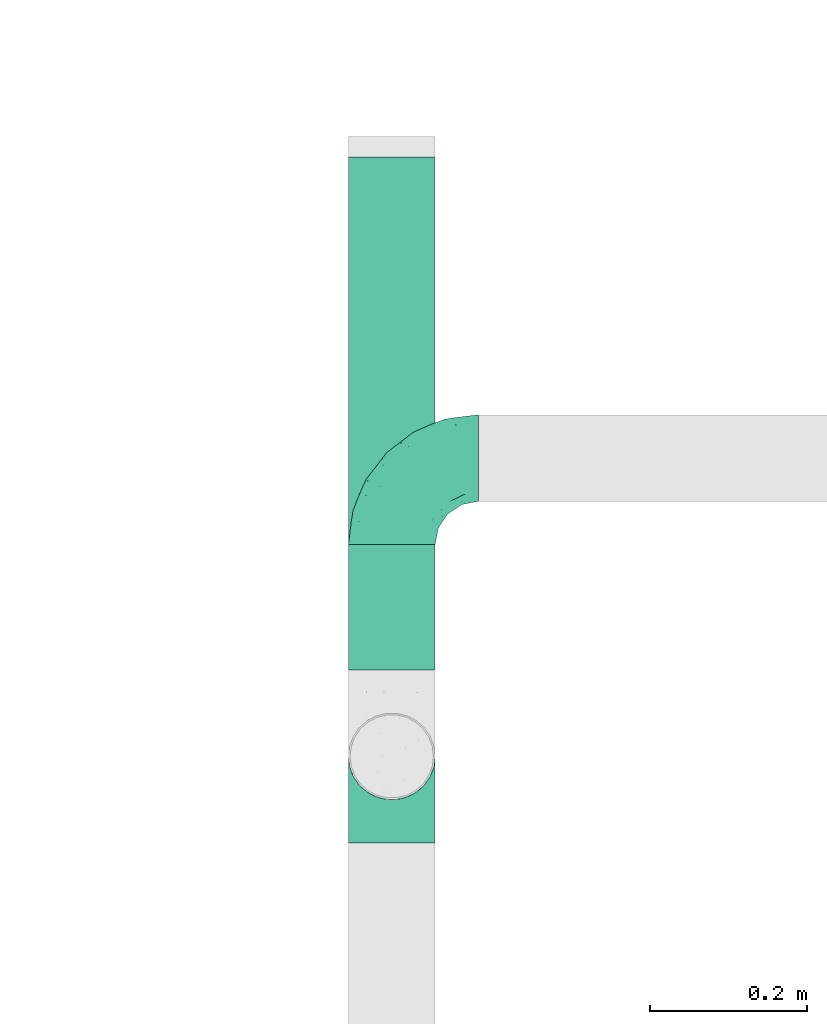
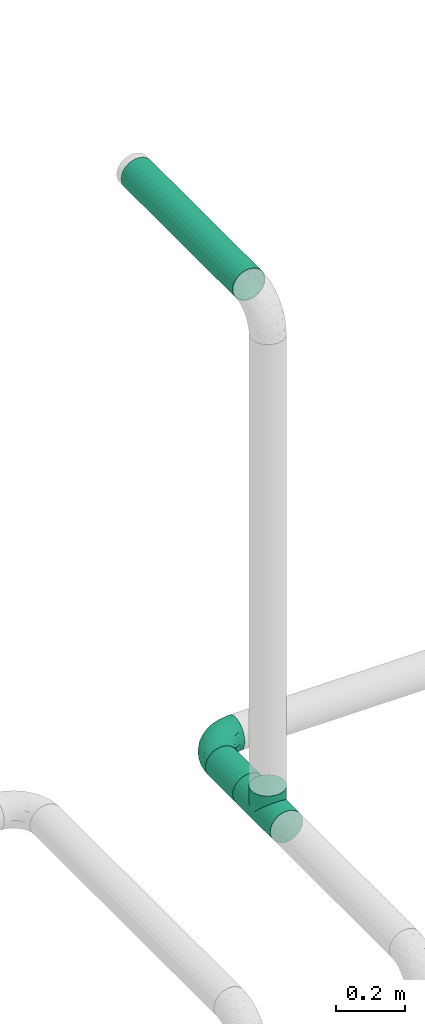
# One storey, part 81 of 103: 2 flow fittings, 2 flow segments.
"""IFC2X3 building model written with IfcOpenShell, lengths in millimetres."""

import ifcopenshell
import ifcopenshell.guid

model = None  # the IFC model being written
_history = None  # IfcOwnerHistory: only IFC2X3 demands one
_inside = {}  # id of a spatial element -> (the spatial element, [elements in it])
_under = {}  # id of a project, library or spatial element -> (it, [spatial elements below it])
_declared = {}  # id of a project -> (the project, [libraries it declares])
_typed = {}  # id of a type object -> (the type object, [elements of that type])
_made_of = {}  # id of a material, layer set ... -> (it, [elements and type objects made of it])


def new_model(schema):
    """Start an empty IFC model of exactly this schema.

    Asked for "IFC4X3", IfcOpenShell would pick the latest addendum, in which some entities
    have other attributes; the version numbers below select the first issue.
    IFC2X3 requires an IfcOwnerHistory on every rooted entity: one is made here for all.
    """
    global model, _history
    if schema == "IFC4X3":
        model = ifcopenshell.file(schema_version=(4, 3, 0, 0))
    else:
        model = ifcopenshell.file(schema=schema)
    _inside.clear()
    _under.clear()
    _declared.clear()
    _typed.clear()
    _made_of.clear()
    _history = None
    if model.schema == "IFC2X3":
        org = make("IfcOrganization", Name="unknown")
        user = make(
            "IfcPersonAndOrganization",
            ThePerson=make("IfcPerson", FamilyName="unknown"),
            TheOrganization=org,
        )
        app = make(
            "IfcApplication",
            ApplicationDeveloper=org,
            Version="unknown",
            ApplicationFullName="unknown",
            ApplicationIdentifier="unknown",
        )
        _history = make(
            "IfcOwnerHistory",
            OwningUser=user,
            OwningApplication=app,
            ChangeAction="ADDED",
            CreationDate=0,
        )
    return model


def make(cls, **values):
    """One entity of the class cls with the attributes given. An attribute that is None is left unset."""
    return model.create_entity(
        cls, **{name: value for name, value in values.items() if value is not None}
    )


def entity(cls, *values):
    """Any entity or typed value of the class cls, its attributes in the order of the schema. None: left unset."""
    e = model.create_entity(cls)
    for i, value in enumerate(values):
        if value is not None:
            e[i] = value
    return e


def rooted(cls, **values):
    """An entity with a GlobalId (a new one), such as an element, a storey or a relation."""
    return make(cls, GlobalId=ifcopenshell.guid.new(), OwnerHistory=_history, **values)


def si_unit(unit_type, name, prefix=None):
    """IfcSIUnit, for example si_unit("LENGTHUNIT", "METRE", prefix="MILLI")."""
    return make("IfcSIUnit", UnitType=unit_type, Prefix=prefix, Name=name)


def converted_unit(unit_type, name, factor, base, dimensions=None, offset=None):
    """IfcConversionBasedUnit, such as the inch: factor (a typed value) times the base unit."""
    return make(
        "IfcConversionBasedUnit"
        if offset is None
        else "IfcConversionBasedUnitWithOffset",
        ConversionOffset=offset,
        Dimensions=None
        if dimensions is None
        else entity("IfcDimensionalExponents", *dimensions),
        UnitType=unit_type,
        Name=name,
        ConversionFactor=make(
            "IfcMeasureWithUnit", ValueComponent=factor, UnitComponent=base
        ),
    )


def derived_unit(unit_type, elements):
    """IfcDerivedUnit: a product of units, each with its exponent."""
    return make(
        "IfcDerivedUnit",
        Elements=[
            make("IfcDerivedUnitElement", Unit=unit, Exponent=power)
            for unit, power in elements
        ],
        UnitType=unit_type,
    )


def assignment(units):
    """IfcUnitAssignment: the units of a project."""
    return None if units is None else make("IfcUnitAssignment", Units=units)


def point(xyz):
    """IfcCartesianPoint."""
    return None if xyz is None else make("IfcCartesianPoint", Coordinates=xyz)


def direction(xyz):
    """IfcDirection."""
    return None if xyz is None else make("IfcDirection", DirectionRatios=xyz)


def frame(location, z_axis=None, x_axis=None):
    """IfcAxis2Placement3D, a coordinate frame: its origin and axes. An axis left out is left unset."""
    return make(
        "IfcAxis2Placement3D",
        Location=point(location),
        Axis=direction(z_axis),
        RefDirection=direction(x_axis),
    )


def frame_2d(location, x_axis=None):
    """IfcAxis2Placement2D, a coordinate frame in the plane: its origin and x axis."""
    return make(
        "IfcAxis2Placement2D", Location=point(location), RefDirection=direction(x_axis)
    )


def origin_with_axes():
    """The frame at (0, 0, 0) with the z axis (0, 0, 1) and the x axis (1, 0, 0) written out."""
    return frame((0.0, 0.0, 0.0), z_axis=(0.0, 0.0, 1.0), x_axis=(1.0, 0.0, 0.0))


def origin_2d_with_axis():
    """The frame at (0, 0) in the plane with the x axis (1, 0) written out."""
    return frame_2d((0.0, 0.0), x_axis=(1.0, 0.0))


def place(relative_to, where):
    """IfcLocalPlacement: puts the frame where relative to a parent placement (None: the world)."""
    return make(
        "IfcLocalPlacement", PlacementRelTo=relative_to, RelativePlacement=where
    )


def context(
    kind, dimensions, precision=None, world=None, true_north=None, identifier=None
):
    """IfcGeometricRepresentationContext, for example the 3D "Model" context."""
    return make(
        "IfcGeometricRepresentationContext",
        ContextIdentifier=identifier,
        ContextType=kind,
        CoordinateSpaceDimension=dimensions,
        Precision=precision,
        WorldCoordinateSystem=world,
        TrueNorth=true_north,
    )


def subcontext(parent, identifier, kind, view, scale=None):
    """IfcGeometricRepresentationSubContext, for example "Body" below "Model"."""
    return make(
        "IfcGeometricRepresentationSubContext",
        ContextIdentifier=identifier,
        ContextType=kind,
        ParentContext=parent,
        TargetScale=scale,
        TargetView=view,
    )


def project(units=None, contexts=None):
    """IfcProject with its units and contexts."""
    return rooted(
        "IfcProject",
        Name="project",
        RepresentationContexts=contexts,
        UnitsInContext=assignment(units),
    )


def spatial(cls, under=None, at=None, **own):
    """A site, building, storey or space (cls), placed at a placement, below another one or the project."""
    s = rooted(cls, ObjectPlacement=at, **own)
    if under is not None:
        _under.setdefault(under.id(), (under, []))[1].append(s)
    return s


def profile(cls, at=None, kind="AREA", **sizes):
    """A parametric profile (cls). Its sizes go by their IFC names, for example OverallWidth=200.0."""
    return make(cls, ProfileType=kind, Position=at, **sizes)


def hollow_circle(**sizes):
    """IfcCircleHollowProfileDef."""
    return profile("IfcCircleHollowProfileDef", **sizes)


def extrude(swept, where, along, depth):
    """IfcExtrudedAreaSolid: the profile swept, set in the frame where, extruded along a direction by depth."""
    return make(
        "IfcExtrudedAreaSolid",
        SweptArea=swept,
        Position=where,
        ExtrudedDirection=direction(along),
        Depth=depth,
    )


def faces_of(points, faces, orient=None, outer=None):
    """IfcFace entities. A face is a list of loops; a loop is a list of indices into points, from 0.

    orient and outer hold one flag for each loop. By default every Orientation is true, the
    first loop of a face is its IfcFaceOuterBound and the others are IfcFaceBound.
    """
    made = []
    for i, loops in enumerate(faces):
        bounds = []
        for j, loop in enumerate(loops):
            is_outer = j == 0 if outer is None else outer[i][j]
            bounds.append(
                make(
                    "IfcFaceOuterBound" if is_outer else "IfcFaceBound",
                    Bound=make("IfcPolyLoop", Polygon=[points[k] for k in loop]),
                    Orientation=True if orient is None else orient[i][j],
                )
            )
        made.append(make("IfcFace", Bounds=bounds))
    return made


def open_shell(faces, orient=None, outer=None):
    """The faces of one IfcOpenShell. surface_model builds it on its shared points."""
    return ("IfcOpenShell", faces, orient, outer)


def surface_model(cls, points, shells):
    """IfcFaceBasedSurfaceModel or IfcShellBasedSurfaceModel (cls): surfaces that need not close."""
    shared = [point(p) for p in points]
    made = [make(c, CfsFaces=faces_of(shared, fs, o, b)) for c, fs, o, b in shells]
    if cls == "IfcFaceBasedSurfaceModel":
        return make(cls, FbsmFaces=made)
    return make(cls, SbsmBoundary=made)


def shape(context_of_items, identifier, shape_type, items):
    """IfcShapeRepresentation: the items that make up one representation, for example the "Body"."""
    return make(
        "IfcShapeRepresentation",
        ContextOfItems=context_of_items,
        RepresentationIdentifier=identifier,
        RepresentationType=shape_type,
        Items=items,
    )


def source(mapping_origin, context_of_items, identifier, shape_type, items):
    """IfcRepresentationMap: a shape defined once, which mapped items show again and again."""
    return make(
        "IfcRepresentationMap",
        MappingOrigin=mapping_origin,
        MappedRepresentation=shape(context_of_items, identifier, shape_type, items),
    )


def transform(
    local_origin,
    x_axis=None,
    y_axis=None,
    z_axis=None,
    scale=None,
    scale2=None,
    scale3=None,
    uniform=True,
):
    """IfcCartesianTransformationOperator3D, or its non-uniform kind. x_axis, y_axis, z_axis: its Axis1, 2, 3."""
    if uniform:
        return make(
            "IfcCartesianTransformationOperator3D",
            Axis1=direction(x_axis),
            Axis2=direction(y_axis),
            LocalOrigin=point(local_origin),
            Scale=scale,
            Axis3=direction(z_axis),
        )
    return make(
        "IfcCartesianTransformationOperator3DnonUniform",
        Axis1=direction(x_axis),
        Axis2=direction(y_axis),
        LocalOrigin=point(local_origin),
        Scale=scale,
        Axis3=direction(z_axis),
        Scale2=scale2,
        Scale3=scale3,
    )


def mapped(mapping_source, mapping_target):
    """IfcMappedItem: shows the shape of a source again, moved by a transform."""
    return make(
        "IfcMappedItem", MappingSource=mapping_source, MappingTarget=mapping_target
    )


def material(Name=None, Category=None):
    """IfcMaterial."""
    return make("IfcMaterial", Name=Name, Category=Category)


def layer(
    of_material, thickness, ventilated=None, Name=None, Category=None, Priority=None
):
    """IfcMaterialLayer: one layer of a wall or slab, of a material (None: an air gap)."""
    return make(
        "IfcMaterialLayer",
        Material=of_material,
        LayerThickness=thickness,
        IsVentilated=ventilated,
        Name=Name,
        Category=Category,
        Priority=Priority,
    )


def layer_set(layers, Name=None):
    """IfcMaterialLayerSet."""
    return make("IfcMaterialLayerSet", MaterialLayers=layers, LayerSetName=Name)


def layer_usage(for_layer_set, set_direction, sense, offset, extent=None):
    """IfcMaterialLayerSetUsage: how a layer set lies in its element."""
    return make(
        "IfcMaterialLayerSetUsage",
        ForLayerSet=for_layer_set,
        LayerSetDirection=set_direction,
        DirectionSense=sense,
        OffsetFromReferenceLine=offset,
        ReferenceExtent=extent,
    )


def made_of(thing, what):
    """Note that an element or type object is made of a material, layer set ...; save() writes the relation."""
    if what is not None:
        _made_of.setdefault(what.id(), (what, []))[1].append(thing)
    return thing


def type_object(cls, material=None, **own):
    """A type object (cls), such as IfcWallType, which elements share."""
    return made_of(rooted(cls, **own), material)


def element(
    cls,
    number,
    at=None,
    inside=None,
    cuts=None,
    type_object=None,
    material=None,
    context=None,
    identifier="Body",
    shape_type=None,
    held_by="IfcProductDefinitionShape",
    body=None,
    shapes=None,
    **own,
):
    """One element of the class cls, such as IfcWall. Its Tag is "e" and its number.

    at: its placement. inside: the storey or other place that contains it. cuts: it is an
    opening in that element (IfcRelVoidsElement). A single representation is given by context,
    identifier, shape_type and body (its items); several are given by shapes. held_by: the class
    of the entity that holds the representations. save() writes the other relations.
    """
    e = rooted(cls, Tag="e%d" % number, ObjectPlacement=at, **own)
    if body is not None:
        shapes = [shape(context, identifier, shape_type, body)]
    if shapes is not None:
        e.Representation = make(held_by, Representations=shapes)
    if inside is not None:
        _inside.setdefault(inside.id(), (inside, []))[1].append(e)
    if cuts is not None:
        rooted(
            "IfcRelVoidsElement", RelatingBuildingElement=cuts, RelatedOpeningElement=e
        )
    if type_object is not None:
        _typed.setdefault(type_object.id(), (type_object, []))[1].append(e)
    return made_of(e, material)


def aggregate(whole, parts):
    """IfcRelAggregates: a whole, such as a stair, and the parts it consists of."""
    return rooted("IfcRelAggregates", RelatingObject=whole, RelatedObjects=parts)


def save(model, path):
    """Write the relations noted so far, then the file.

    IfcRelAggregates (storeys below a building ...), IfcRelContainedInSpatialStructure (elements
    in a storey), IfcRelDefinesByType, IfcRelAssociatesMaterial and IfcRelDeclares: one each for
    every whole, place, type object, material and project.
    """
    for whole, parts in _under.values():
        aggregate(whole, parts)
    for where, things in _inside.values():
        rooted(
            "IfcRelContainedInSpatialStructure",
            RelatedElements=things,
            RelatingStructure=where,
        )
    for kind, things in _typed.values():
        rooted("IfcRelDefinesByType", RelatedObjects=things, RelatingType=kind)
    for what, things in _made_of.values():
        rooted("IfcRelAssociatesMaterial", RelatedObjects=things, RelatingMaterial=what)
    for by, libraries in _declared.values():
        rooted("IfcRelDeclares", RelatingContext=by, RelatedDefinitions=libraries)
    model.write(path)


model = new_model("IFC2X3")

# Units and contexts
model_context = context("Model", 3, precision=1e-05, world=origin_with_axes(), true_north=direction((0.0, 1.0)))
body_context = subcontext(model_context, "Body", "Model", "MODEL_VIEW")
ifc_project = project(units=[si_unit("AREAUNIT", "SQUARE_METRE"), si_unit("VOLUMEUNIT", "CUBIC_METRE", prefix="DECI"), si_unit("TIMEUNIT", "SECOND"), si_unit("THERMODYNAMICTEMPERATUREUNIT", "DEGREE_CELSIUS"), si_unit("PRESSUREUNIT", "PASCAL"), si_unit("MASSUNIT", "GRAM", prefix="KILO"), si_unit("LENGTHUNIT", "METRE", prefix="MILLI"), si_unit("POWERUNIT", "WATT"), si_unit("ELECTRICCURRENTUNIT", "AMPERE"), si_unit("ELECTRICVOLTAGEUNIT", "VOLT"), derived_unit("VOLUMETRICFLOWRATEUNIT", [(si_unit("VOLUMEUNIT", "CUBIC_METRE", prefix="DECI"), 1), (si_unit("TIMEUNIT", "SECOND"), -1)]), derived_unit("LINEARVELOCITYUNIT", [(si_unit("LENGTHUNIT", "METRE"), 1), (si_unit("TIMEUNIT", "SECOND"), -1)]), derived_unit("MASSDENSITYUNIT", [(si_unit("MASSUNIT", "GRAM", prefix="KILO"), 1), (si_unit("VOLUMEUNIT", "CUBIC_METRE"), -1)]), converted_unit("PLANEANGLEUNIT", "DEGREE", entity("IfcRatioMeasure", 0.01745), si_unit("PLANEANGLEUNIT", "RADIAN"), dimensions=[0, 0, 0, 0, 0, 0, 0])], contexts=[model_context])

# Site, building, storey
site_placement = place(None, origin_with_axes())
site = spatial("IfcSite", under=ifc_project, at=site_placement, CompositionType="ELEMENT")
building_placement = place(site_placement, origin_with_axes())
building = spatial("IfcBuilding", under=site, at=building_placement, Name="mc-building", CompositionType="ELEMENT")
storey_placement = place(building_placement, frame((0.0, 0.0, 5900.0), z_axis=(0.0, 0.0, 1.0), x_axis=(1.0, 0.0, 0.0)))
storey = spatial("IfcBuildingStorey", under=building, at=storey_placement, Name="3. Korrus", CompositionType="ELEMENT", Elevation=5900.0)

# Flow fittings
duct_fitting_type_1 = type_object("IfcDuctFittingType", PredefinedType="JUNCTION")
shared_shape_1 = source(origin_with_axes(), body_context, "Body", "SurfaceModel", [
    surface_model("IfcShellBasedSurfaceModel", [(0.0, -80.0, -55.0), (14.23505, -80.0, -53.12592), (-14.23505, -80.0, -53.12592), (-53.12592, -80.0, 14.23505), (-27.5, -80.0, -47.63139), (-47.63139, -80.0, -27.5), (-38.89087, -80.0, -38.89087), (55.0, -80.0, 0.0), (53.12592, -80.0, 14.23505), (38.89087, -80.0, -38.89087), (27.5, -80.0, -47.63139), (53.12592, -80.0, -14.23505), (47.63139, -80.0, -27.5), (-53.12592, -80.0, -14.23505), (-47.63139, -80.0, 27.5), (-38.89087, -80.0, 38.89087), (14.23505, -80.0, 53.12592), (-27.5, -80.0, 47.63139), (-14.23505, -80.0, 53.12592), (47.63139, -80.0, 27.5), (38.89087, -80.0, 38.89087), (27.5, -80.0, 47.63139), (0.0, -80.0, 55.0), (-55.0, -80.0, 0.0), (0.0, 0.0, 55.0), (-7.4066, -7.4066, 54.49901), (-14.74521, -14.74521, 52.98659), (-21.93978, -21.93978, 50.43457), (-28.89905, -28.89905, 46.79578), (-35.50357, -35.50357, 42.00591), (-41.58668, -41.58668, 35.99373), (-46.92319, -46.92319, 28.69171), (-51.19777, -51.19777, 20.0945), (-50.37866, -80.0, 20.86752), (-54.01174, -54.01174, 10.37938), (-55.0, -55.0, 0.0), (-54.06296, -80.0, 7.11752), (-54.01174, -54.01174, -10.37938), (-51.19777, -51.19777, -20.0945), (-54.06296, -80.0, -7.11752), (-46.92319, -46.92319, -28.69171), (-41.58668, -41.58668, -35.99373), (-50.37866, -80.0, -20.86752), (-35.50357, -35.50357, -42.00591), (-21.93978, -21.93978, -50.43457), (-14.74521, -14.74521, -52.98659), (-7.4066, -7.4066, -54.49901), (0.0, 0.0, -55.0), (-28.89905, -28.89905, -46.79578), (7.4066, -7.4066, -54.49901), (14.74521, -14.74521, -52.98659), (21.93978, -21.93978, -50.43457), (28.89905, -28.89905, -46.79578), (35.50357, -35.50357, -42.00591), (41.58668, -41.58668, -35.99373), (46.92319, -46.92319, -28.69171), (51.19777, -51.19777, -20.0945), (50.37866, -80.0, -20.86752), (54.01174, -54.01174, -10.37938), (55.0, -55.0, 0.0), (54.06296, -80.0, -7.11752), (54.01174, -54.01174, 10.37938), (51.19777, -51.19777, 20.0945), (54.06296, -80.0, 7.11752), (46.92319, -46.92319, 28.69171), (41.58668, -41.58668, 35.99373), (50.37866, -80.0, 20.86752), (35.50357, -35.50357, 42.00591), (21.93978, -21.93978, 50.43457), (14.74521, -14.74521, 52.98659), (7.4066, -7.4066, 54.49901), (28.89905, -28.89905, 46.79578), (-110.0, 0.0, -55.0), (-110.0, -14.23505, -53.12592), (-110.0, 14.23505, -53.12592), (-110.0, 53.12592, 14.23505), (-110.0, 27.5, -47.63139), (-110.0, 47.63139, -27.5), (-110.0, 38.89087, -38.89087), (-110.0, -55.0, 0.0), (-110.0, -53.12592, 14.23505), (-110.0, -38.89087, -38.89087), (-110.0, -27.5, -47.63139), (-110.0, -53.12592, -14.23505), (-110.0, -47.63139, -27.5), (-110.0, 53.12592, -14.23505), (-110.0, 47.63139, 27.5), (-110.0, 38.89087, 38.89087), (-110.0, -14.23505, 53.12592), (-110.0, 27.5, 47.63139), (-110.0, 14.23505, 53.12592), (-110.0, -47.63139, 27.5), (-110.0, -38.89087, 38.89087), (-110.0, -27.5, 47.63139), (-110.0, 0.0, 55.0), (-110.0, 55.0, 0.0), (110.0, 55.0, 0.0), (110.0, 0.0, -55.0), (110.0, 14.23505, -53.12592), (110.0, 27.5, -47.63139), (110.0, 38.89087, -38.89087), (110.0, 47.63139, -27.5), (110.0, -38.89087, -38.89087), (110.0, -53.12592, 14.23505), (110.0, -27.5, -47.63139), (110.0, -14.23505, -53.12592), (110.0, -47.63139, -27.5), (110.0, -53.12592, -14.23505), (110.0, -55.0, 0.0), (110.0, 53.12592, -14.23505), (110.0, 53.12592, 14.23505), (110.0, 47.63139, 27.5), (110.0, 38.89087, 38.89087), (110.0, 0.0, 55.0), (110.0, 27.5, 47.63139), (110.0, 14.23505, 53.12592), (110.0, -47.63139, 27.5), (110.0, -38.89087, 38.89087), (110.0, -27.5, 47.63139), (110.0, -14.23505, 53.12592)], [open_shell([[[0, 1, 2]], [[2, 3, 4]], [[5, 6, 3]], [[6, 4, 3]], [[2, 7, 8]], [[9, 7, 10]], [[1, 10, 7]], [[11, 7, 12]], [[9, 12, 7]], [[7, 2, 1]], [[5, 3, 13]], [[2, 14, 3]], [[2, 15, 14]], [[2, 16, 17]], [[17, 15, 2]], [[16, 18, 17]], [[2, 8, 19]], [[2, 19, 20]], [[2, 20, 21]], [[16, 2, 21]], [[16, 22, 18]], [[23, 13, 3]], [[24, 25, 22]], [[26, 27, 18]], [[25, 26, 18]], [[22, 25, 18]], [[17, 28, 29]], [[17, 18, 27]], [[17, 29, 15]], [[28, 17, 27]], [[30, 31, 14]], [[32, 3, 33]], [[32, 34, 3]], [[35, 36, 34]], [[31, 32, 14]], [[15, 30, 14]], [[34, 36, 3]], [[33, 14, 32]], [[36, 35, 23]], [[30, 15, 29]], [[37, 38, 13]], [[37, 13, 39]], [[40, 41, 5]], [[38, 5, 42]], [[38, 40, 5]], [[37, 39, 35]], [[35, 39, 23]], [[13, 38, 42]], [[41, 6, 5]], [[41, 43, 6]], [[44, 45, 2]], [[46, 47, 0]], [[45, 46, 2]], [[43, 48, 4]], [[44, 4, 48]], [[44, 2, 4]], [[46, 0, 2]], [[43, 4, 6]], [[47, 49, 0]], [[50, 51, 1]], [[49, 50, 1]], [[0, 49, 1]], [[10, 52, 53]], [[10, 1, 51]], [[10, 53, 9]], [[52, 10, 51]], [[54, 55, 12]], [[56, 11, 57]], [[56, 58, 11]], [[59, 60, 58]], [[55, 56, 12]], [[9, 54, 12]], [[58, 60, 11]], [[57, 12, 56]], [[60, 59, 7]], [[54, 9, 53]], [[61, 62, 8]], [[61, 8, 63]], [[64, 65, 19]], [[62, 19, 66]], [[62, 64, 19]], [[61, 63, 59]], [[7, 59, 63]], [[62, 66, 8]], [[65, 20, 19]], [[65, 67, 20]], [[68, 69, 16]], [[70, 24, 22]], [[69, 70, 16]], [[67, 71, 21]], [[68, 21, 71]], [[68, 16, 21]], [[70, 22, 16]], [[67, 21, 20]], [[72, 73, 74]], [[74, 75, 76]], [[77, 78, 75]], [[76, 75, 78]], [[74, 79, 80]], [[81, 79, 82]], [[73, 82, 79]], [[83, 79, 84]], [[81, 84, 79]], [[79, 74, 73]], [[77, 75, 85]], [[74, 86, 75]], [[74, 87, 86]], [[74, 88, 89]], [[89, 87, 74]], [[88, 90, 89]], [[74, 91, 92]], [[91, 74, 80]], [[92, 93, 74]], [[74, 93, 88]], [[88, 94, 90]], [[95, 85, 75]], [[96, 97, 98]], [[99, 96, 98]], [[96, 100, 101]], [[100, 96, 99]], [[102, 97, 103]], [[97, 102, 104]], [[104, 105, 97]], [[102, 103, 106]], [[106, 103, 107]], [[108, 107, 103]], [[109, 96, 101]], [[110, 111, 97]], [[97, 111, 112]], [[113, 97, 114]], [[97, 112, 114]], [[113, 114, 115]], [[116, 103, 97]], [[117, 116, 97]], [[118, 117, 97]], [[119, 118, 97]], [[119, 97, 113]], [[96, 110, 97]], [[24, 113, 115]], [[89, 115, 114]], [[94, 24, 90]], [[90, 24, 115]], [[115, 89, 90]], [[114, 87, 89]], [[86, 112, 111]], [[75, 111, 110]], [[95, 110, 96]], [[87, 112, 86]], [[86, 111, 75]], [[110, 95, 75]], [[112, 87, 114]], [[85, 96, 109]], [[77, 109, 101]], [[95, 96, 85]], [[85, 109, 77]], [[101, 78, 77]], [[101, 100, 78]], [[76, 100, 99]], [[74, 99, 98]], [[47, 98, 97]], [[76, 99, 74]], [[47, 72, 74]], [[98, 47, 74]], [[100, 76, 78]], [[47, 46, 72]], [[45, 44, 73]], [[46, 45, 73]], [[72, 46, 73]], [[82, 48, 43]], [[82, 73, 44]], [[82, 43, 81]], [[48, 82, 44]], [[41, 40, 84]], [[38, 37, 83]], [[40, 38, 84]], [[81, 41, 84]], [[37, 79, 83]], [[83, 84, 38]], [[79, 37, 35]], [[41, 81, 43]], [[49, 97, 105]], [[105, 104, 51]], [[53, 104, 102]], [[53, 52, 104]], [[49, 47, 97]], [[51, 50, 105]], [[52, 51, 104]], [[49, 105, 50]], [[54, 102, 106]], [[56, 106, 107]], [[58, 107, 108]], [[55, 54, 106]], [[58, 56, 107]], [[59, 58, 108]], [[55, 106, 56]], [[102, 54, 53]], [[34, 32, 80]], [[31, 30, 91]], [[32, 31, 91]], [[35, 34, 79]], [[80, 79, 34]], [[32, 91, 80]], [[30, 92, 91]], [[30, 29, 92]], [[27, 26, 88]], [[25, 24, 94]], [[26, 25, 88]], [[29, 28, 93]], [[27, 93, 28]], [[27, 88, 93]], [[25, 94, 88]], [[29, 93, 92]], [[61, 108, 103]], [[62, 103, 116]], [[65, 116, 117]], [[61, 59, 108]], [[64, 62, 116]], [[65, 64, 116]], [[61, 103, 62]], [[117, 67, 65]], [[71, 67, 118]], [[118, 67, 117]], [[68, 118, 119]], [[70, 119, 113]], [[68, 71, 118]], [[70, 69, 119]], [[24, 70, 113]], [[68, 119, 69]]])]),
])
flow_fitting_1_placement = place(storey_placement, frame((26894.1474, 9098.55564, 2345.0), z_axis=(1.0, 0.0, 0.0), x_axis=(0.0, -1.0, 0.0)))
element("IfcFlowFitting", 1, at=flow_fitting_1_placement, inside=storey, type_object=duct_fitting_type_1, context=body_context, shape_type="MappedRepresentation", body=[
    mapped(shared_shape_1, transform((0.0, 0.0, 0.0), scale=1.0)),
])
duct_fitting_type_2 = type_object("IfcDuctFittingType", Name="BU", PredefinedType="BEND")
shared_shape_2 = source(origin_with_axes(), body_context, "Body", "SurfaceModel", [
    surface_model("IfcShellBasedSurfaceModel", [(-110.0, 0.0, -55.0), (-110.0, -14.23505, -53.12592), (-110.0, 14.23505, -53.12592), (-110.0, 53.12592, 14.23505), (-110.0, 27.5, -47.63139), (-110.0, 38.89087, -38.89087), (-110.0, -55.0, 0.0), (-110.0, -53.12592, 14.23505), (-110.0, -38.89087, -38.89087), (-110.0, -27.5, -47.63139), (-110.0, -53.12592, -14.23505), (-110.0, -47.63139, -27.5), (-110.0, -14.23505, 53.12592), (-110.0, 14.23505, 53.12592), (-110.0, 27.5, 47.63139), (-110.0, -47.63139, 27.5), (-110.0, -38.89087, 38.89087), (-110.0, -27.5, 47.63139), (-110.0, 0.0, 55.0), (-110.0, 55.0, 0.0), (-110.0, 53.12592, -14.23505), (-110.0, 47.63139, -27.5), (-110.0, 47.63139, 27.5), (-110.0, 38.89087, 38.89087), (-14.23505, 110.0, -53.12592), (-55.0, 110.0, 0.0), (0.0, 110.0, -55.0), (-27.5, 110.0, -47.63139), (-38.89087, 110.0, -38.89087), (-47.63139, 110.0, -27.5), (38.89087, 110.0, -38.89087), (53.12592, 110.0, 14.23505), (27.5, 110.0, -47.63139), (14.23505, 110.0, -53.12592), (47.63139, 110.0, -27.5), (53.12592, 110.0, -14.23505), (55.0, 110.0, 0.0), (-53.12592, 110.0, -14.23505), (-53.12592, 110.0, 14.23505), (-47.63139, 110.0, 27.5), (-38.89087, 110.0, 38.89087), (-27.5, 110.0, 47.63139), (0.0, 110.0, 55.0), (-14.23505, 110.0, 53.12592), (38.89087, 110.0, 38.89087), (47.63139, 110.0, 27.5), (27.5, 110.0, 47.63139), (14.23505, 110.0, 53.12592), (-64.21732, 48.68956, 43.63444), (-76.6405, 38.18013, 45.55988), (-60.44912, 32.56953, 51.94617), (-76.00813, 5.38378, 55.0), (-90.15553, 11.94394, 54.09138), (-78.5998, 26.77405, 50.81338), (-70.18771, 18.55163, 54.03432), (-75.55424, 54.2118, 32.41257), (-93.27622, 45.77614, 33.48188), (-96.12334, 22.13664, 50.81337), (-21.00813, 45.34362, 55.0), (-18.36258, 70.48427, 54.04484), (-32.04182, 59.64019, 52.24446), (-63.88653, 74.77858, 17.99134), (-74.66383, 63.08407, 19.92123), (-63.60674, 66.07878, 29.97482), (-99.597, 52.72185, 18.52927), (-93.11138, 56.59448, 10.50359), (-98.21577, 57.34403, 0.0), (-53.42855, 92.60092, 21.04759), (-88.54852, 54.8376, 21.04759), (-11.86161, 90.23965, 54.10313), (-5.38378, 76.00813, 55.0), (-57.34403, 98.21577, 0.0), (-56.64619, 93.12774, 10.22088), (-45.34362, 21.00813, 55.0), (-44.60838, 44.60838, 52.13415), (-92.68484, 35.46673, 43.63443), (-22.25266, 95.40765, 50.81337), (-35.97783, 90.61597, 43.63443), (-43.70931, 69.58671, 44.47149), (-27.23711, 77.39884, 50.81337), (-57.2828, 79.3123, 24.9774), (-58.67786, 84.31125, 16.04456), (-82.93277, 60.36161, 12.91784), (-49.88337, 54.51816, 47.224), (-74.57753, 66.83759, 9.55742), (-45.35812, 94.97281, 33.48188), (-59.18663, 88.95241, 0.0), (-51.517, 78.6292, 33.48188), (-65.14788, 80.03077, 0.0), (-56.45322, 62.06476, 39.63545), (-88.95241, 59.18663, 0.0), (-71.10913, 71.10913, 0.0), (-80.03077, 65.14788, 0.0), (-94.9309, 45.36788, -33.48188), (-93.11358, 56.60141, -10.46614), (-99.64997, 52.79499, -18.30015), (-90.20425, 36.08686, -43.63443), (-79.99933, 46.56772, -37.92748), (-76.00813, 5.38378, -55.0), (-72.75364, 19.68651, -53.60527), (-45.34362, 21.00813, -55.0), (-21.91957, 65.12078, -53.85897), (-5.38378, 76.00813, -55.0), (-21.00813, 45.34362, -55.0), (-35.41876, 92.89265, -43.63443), (-91.10309, 11.02766, -54.21832), (-45.77614, 93.27622, -33.48188), (-90.50474, 23.21022, -50.81337), (-70.92854, 33.31794, -49.51754), (-78.52933, 63.35627, -11.73997), (-24.91508, 84.05606, -50.81337), (-88.78941, 54.74452, -21.04759), (-69.59921, 57.34866, -33.48187), (-73.36422, 62.46673, -22.94182), (-63.49062, 67.59111, -28.46929), (-56.59448, 93.11138, -10.50359), (-54.8376, 88.54852, -21.04759), (-54.10679, 75.85581, -32.31867), (-57.75956, 31.09612, -52.80882), (-52.72185, 99.597, -18.52927), (-12.62913, 89.46304, -53.99097), (-34.46825, 66.46123, -50.04329), (-43.9837, 43.9837, -52.42279), (-65.78527, 72.58348, -17.68796), (-70.34468, 43.65295, -44.21951), (-57.47001, 51.99467, -44.91465), (-60.72547, 82.29174, -12.88567), (-42.34915, 74.24548, -43.63444), (-57.25194, 63.5016, -38.08211), (-80.95344, 53.56991, -29.32027), (-52.32891, 4.55257, -54.0482), (32.52942, 47.13398, -30.48571), (14.88266, 20.92917, -33.7947), (14.95561, 36.05775, -42.26543), (30.24048, 70.09027, -41.7461), (19.3559, 65.35825, -48.00507), (-70.35075, -46.44478, -19.5952), (-47.13398, -32.52942, -30.48571), (-28.49299, -30.5778, -16.4009), (-4.55257, 52.32891, -54.0482), (-22.4954, 22.4954, -53.25347), (-75.47368, -11.22546, -52.60718), (-81.32209, -51.5606, -9.98467), (-80.81763, -41.84862, -32.14655), (-70.09027, -30.24048, -41.7461), (-36.05774, -14.95561, -42.26543), (-9.15831, -10.852, -27.8997), (-65.35825, -19.3559, -48.00507), (11.22546, 75.47368, -52.60718), (3.94376, 43.9333, -50.53315), (-13.39742, 13.39743, -48.13058), (-43.9333, -3.94376, -50.53315), (49.37776, 67.29486, 0.0), (41.8609, 47.82256, -9.92641), (50.20582, 74.51695, -9.9731), (18.93131, 11.7156, -17.56239), (-27.5, -32.89419, 0.0), (-1.23348, -12.25375, -12.18106), (41.84862, 80.81763, -32.14655), (35.70604, 41.31408, -20.38235), (46.44478, 70.35075, -19.5952), (32.89419, 27.5, 0.0), (6.67262, -6.67262, 0.0), (-67.29486, -49.37776, 0.0), (-50.36265, -42.95545, -9.51562), (-5.47251, 5.47251, -39.92906), (-70.35075, -46.44478, 19.5952), (-74.51695, -50.20582, 9.9731), (-41.31407, -35.70604, 20.38235), (-47.13398, -32.52942, 30.48571), (-80.81763, -41.84862, 32.14655), (-4.55257, 52.32891, 54.0482), (11.22546, 75.47368, 52.60718), (-43.9333, -3.94376, 50.53315), (-65.35825, -19.3559, 48.00507), (-36.05774, -14.95561, 42.26543), (-70.09027, -30.24048, 41.7461), (-11.7156, -18.93131, 17.56239), (30.5778, 28.49299, 16.4009), (12.25375, 1.23348, 12.18106), (51.5606, 81.32209, 9.98467), (42.95545, 50.36265, 9.51562), (-75.47368, -11.22546, 52.60718), (-52.32891, 4.55257, 54.0482), (3.94376, 43.9333, 50.53315), (-22.4954, 22.4954, 53.25347), (-13.39742, 13.39743, 48.13058), (10.852, 9.15831, 27.8997), (-20.92916, -14.88266, 33.79469), (-47.82256, -41.8609, 9.92641), (32.52942, 47.13398, 30.48571), (46.44478, 70.35075, 19.5952), (41.84862, 80.81763, 32.14655), (30.24048, 70.09027, 41.7461), (19.3559, 65.35825, 48.00507), (14.95561, 36.05775, 42.26543), (-5.47251, 5.47251, 39.92906)], [open_shell([[[0, 1, 2]], [[2, 3, 4]], [[4, 3, 5]], [[2, 6, 7]], [[8, 6, 9]], [[1, 9, 6]], [[10, 6, 11]], [[8, 11, 6]], [[6, 2, 1]], [[12, 13, 14]], [[15, 2, 7]], [[16, 17, 2]], [[2, 17, 12]], [[12, 18, 13]], [[19, 20, 3]], [[5, 3, 21]], [[20, 21, 3]], [[22, 3, 2]], [[23, 22, 2]], [[12, 14, 2]], [[2, 14, 23]], [[15, 16, 2]], [[24, 25, 26]], [[27, 25, 24]], [[25, 28, 29]], [[28, 25, 27]], [[30, 26, 31]], [[26, 30, 32]], [[32, 33, 26]], [[34, 31, 35]], [[31, 34, 30]], [[35, 31, 36]], [[29, 37, 25]], [[38, 39, 26]], [[39, 40, 26]], [[41, 42, 40]], [[42, 26, 40]], [[42, 41, 43]], [[26, 44, 45]], [[31, 26, 45]], [[26, 46, 44]], [[47, 46, 26]], [[42, 47, 26]], [[25, 38, 26]], [[48, 49, 50]], [[18, 51, 52]], [[53, 54, 50]], [[55, 56, 49]], [[56, 22, 23]], [[13, 57, 14]], [[58, 59, 60]], [[61, 62, 63]], [[3, 64, 65]], [[53, 52, 54]], [[3, 65, 66]], [[67, 39, 38]], [[56, 68, 64]], [[65, 64, 68]], [[69, 59, 70]], [[38, 71, 72]], [[73, 58, 74]], [[75, 49, 56]], [[76, 69, 43]], [[53, 57, 52]], [[77, 78, 79]], [[41, 76, 43]], [[43, 69, 42]], [[55, 68, 56]], [[23, 14, 75]], [[76, 77, 79]], [[80, 67, 81]], [[62, 82, 68]], [[60, 78, 83]], [[62, 84, 82]], [[85, 77, 40]], [[81, 67, 72]], [[86, 72, 71]], [[87, 85, 67]], [[61, 81, 88]], [[77, 41, 40]], [[78, 77, 87]], [[23, 75, 56]], [[83, 89, 48]], [[85, 40, 39]], [[62, 68, 55]], [[89, 87, 63]], [[83, 48, 50]], [[57, 75, 14]], [[49, 75, 53]], [[67, 85, 39]], [[87, 77, 85]], [[63, 62, 55]], [[89, 55, 48]], [[80, 63, 87]], [[66, 65, 90]], [[66, 19, 3]], [[84, 91, 92]], [[92, 90, 82]], [[65, 82, 90]], [[61, 84, 62]], [[92, 82, 84]], [[68, 82, 65]], [[3, 22, 64]], [[56, 64, 22]], [[38, 25, 71]], [[81, 72, 86]], [[38, 72, 67]], [[91, 61, 88]], [[80, 81, 61]], [[63, 80, 61]], [[67, 80, 87]], [[77, 76, 41]], [[79, 59, 69]], [[79, 69, 76]], [[42, 69, 70]], [[60, 59, 79]], [[58, 70, 59]], [[78, 60, 79]], [[58, 60, 74]], [[52, 57, 13]], [[75, 57, 53]], [[18, 52, 13]], [[52, 51, 54]], [[51, 73, 54]], [[50, 73, 74]], [[73, 50, 54]], [[50, 74, 83]], [[60, 83, 74]], [[89, 83, 78]], [[87, 89, 78]], [[55, 89, 63]], [[50, 49, 53]], [[55, 49, 48]], [[81, 86, 88]], [[91, 84, 61]], [[5, 21, 93]], [[90, 94, 66]], [[20, 94, 95]], [[96, 93, 97]], [[98, 99, 100]], [[96, 4, 5]], [[101, 102, 103]], [[28, 27, 104]], [[2, 105, 0]], [[104, 106, 28]], [[99, 105, 107]], [[108, 107, 96]], [[90, 109, 94]], [[107, 2, 4]], [[20, 66, 94]], [[27, 24, 110]], [[109, 111, 94]], [[112, 113, 114]], [[37, 115, 71]], [[116, 106, 117]], [[99, 118, 100]], [[116, 115, 119]], [[37, 119, 115]], [[24, 120, 110]], [[121, 110, 101]], [[119, 106, 116]], [[101, 110, 120]], [[122, 103, 100]], [[117, 123, 116]], [[124, 125, 108]], [[115, 116, 126]], [[106, 29, 28]], [[26, 102, 120]], [[127, 104, 110]], [[97, 124, 96]], [[125, 122, 118]], [[128, 127, 125]], [[96, 5, 93]], [[115, 126, 86]], [[117, 106, 127]], [[111, 113, 129]], [[95, 93, 21]], [[97, 129, 112]], [[110, 104, 27]], [[106, 104, 127]], [[96, 107, 4]], [[99, 107, 108]], [[99, 108, 118]], [[105, 99, 98]], [[112, 114, 128]], [[121, 125, 127]], [[20, 19, 66]], [[109, 90, 92]], [[94, 111, 95]], [[91, 123, 109]], [[129, 113, 112]], [[93, 95, 111]], [[21, 20, 95]], [[71, 115, 86]], [[71, 25, 37]], [[123, 91, 88]], [[126, 116, 123]], [[123, 88, 126]], [[86, 126, 88]], [[37, 29, 119]], [[106, 119, 29]], [[129, 93, 111]], [[124, 112, 125]], [[0, 105, 98]], [[107, 105, 2]], [[125, 118, 108]], [[100, 118, 122]], [[93, 129, 97]], [[113, 111, 109]], [[109, 123, 113]], [[114, 123, 117]], [[123, 114, 113]], [[128, 114, 117]], [[127, 128, 117]], [[112, 128, 125]], [[103, 122, 101]], [[110, 121, 127]], [[101, 122, 121]], [[125, 121, 122]], [[26, 120, 24]], [[101, 120, 102]], [[96, 124, 108]], [[92, 91, 109]], [[112, 124, 97]], [[100, 130, 98]], [[131, 132, 133]], [[32, 134, 135]], [[136, 137, 138]], [[139, 140, 103]], [[98, 141, 0]], [[142, 10, 136]], [[143, 144, 137]], [[6, 10, 142]], [[137, 145, 146]], [[144, 147, 145]], [[143, 136, 11]], [[11, 136, 10]], [[8, 143, 11]], [[148, 149, 139]], [[8, 9, 144]], [[9, 1, 147]], [[130, 141, 98]], [[103, 140, 100]], [[148, 135, 149]], [[150, 151, 140]], [[152, 153, 154]], [[130, 140, 151]], [[148, 26, 33]], [[147, 1, 141]], [[155, 146, 132]], [[156, 138, 157]], [[134, 30, 158]], [[150, 140, 149]], [[158, 30, 34]], [[30, 134, 32]], [[153, 159, 160]], [[131, 160, 159]], [[144, 145, 137]], [[36, 152, 154]], [[146, 138, 137]], [[155, 161, 162]], [[158, 160, 131]], [[133, 149, 135]], [[156, 163, 164]], [[163, 142, 164]], [[139, 103, 102]], [[153, 152, 161]], [[34, 35, 160]], [[162, 157, 155]], [[132, 165, 133]], [[157, 146, 155]], [[140, 130, 100]], [[141, 130, 151]], [[141, 151, 147]], [[141, 1, 0]], [[102, 26, 148]], [[140, 139, 149]], [[102, 148, 139]], [[135, 33, 32]], [[151, 150, 145]], [[9, 147, 144]], [[151, 145, 147]], [[145, 165, 146]], [[135, 148, 33]], [[133, 135, 134]], [[131, 133, 134]], [[133, 165, 150]], [[133, 150, 149]], [[145, 150, 165]], [[132, 131, 159]], [[146, 165, 132]], [[160, 158, 34]], [[134, 158, 131]], [[144, 143, 8]], [[136, 143, 137]], [[155, 153, 161]], [[154, 153, 160]], [[153, 155, 159]], [[132, 159, 155]], [[160, 35, 154]], [[36, 154, 35]], [[164, 136, 138]], [[6, 142, 163]], [[136, 164, 142]], [[156, 164, 138]], [[156, 157, 162]], [[146, 157, 138]], [[15, 7, 166]], [[6, 163, 167]], [[168, 169, 166]], [[166, 169, 170]], [[171, 172, 70]], [[173, 174, 175]], [[17, 176, 174]], [[177, 156, 162]], [[176, 16, 170]], [[170, 16, 15]], [[161, 178, 179]], [[152, 180, 181]], [[182, 173, 183]], [[18, 12, 182]], [[184, 185, 186]], [[183, 185, 73]], [[183, 73, 51]], [[177, 187, 188]], [[189, 168, 166]], [[187, 178, 190]], [[16, 176, 17]], [[161, 152, 181]], [[45, 191, 31]], [[45, 44, 192]], [[192, 191, 45]], [[180, 36, 31]], [[193, 194, 195]], [[46, 47, 194]], [[193, 195, 190]], [[193, 44, 46]], [[172, 42, 70]], [[185, 58, 73]], [[189, 163, 156]], [[163, 189, 167]], [[70, 58, 171]], [[184, 171, 185]], [[169, 188, 175]], [[180, 31, 191]], [[192, 193, 190]], [[191, 190, 178]], [[182, 174, 173]], [[194, 47, 172]], [[190, 195, 187]], [[186, 185, 173]], [[162, 179, 177]], [[188, 196, 175]], [[179, 187, 177]], [[185, 171, 58]], [[172, 171, 184]], [[172, 184, 194]], [[172, 47, 42]], [[51, 18, 182]], [[185, 183, 173]], [[51, 182, 183]], [[174, 12, 17]], [[184, 186, 195]], [[46, 194, 193]], [[184, 195, 194]], [[195, 196, 187]], [[174, 182, 12]], [[175, 174, 176]], [[169, 175, 176]], [[175, 196, 186]], [[175, 186, 173]], [[195, 186, 196]], [[188, 169, 168]], [[187, 196, 188]], [[166, 170, 15]], [[176, 170, 169]], [[193, 192, 44]], [[191, 192, 190]], [[177, 189, 156]], [[167, 189, 166]], [[189, 177, 168]], [[188, 168, 177]], [[166, 7, 167]], [[6, 167, 7]], [[181, 191, 178]], [[36, 180, 152]], [[191, 181, 180]], [[161, 181, 178]], [[161, 179, 162]], [[187, 179, 178]]])]),
])
flow_fitting_2_placement = place(storey_placement, frame((26894.1474, 9477.62755, 2345.0), z_axis=(0.0, 0.0, 1.0), x_axis=(-1.0, 0.0, 0.0)))
element("IfcFlowFitting", 2, at=flow_fitting_2_placement, inside=storey, type_object=duct_fitting_type_2, Name="BU", context=body_context, shape_type="MappedRepresentation", body=[
    mapped(shared_shape_2, transform((0.0, 0.0, 0.0), scale=1.0)),
])

# Flow segments
ifc_material = material(Name="FZ1")
ifc_layer = layer(ifc_material, 0.0)
ifc_layer_set = layer_set([ifc_layer], Name="FZ1")
ifc_layer_usage = layer_usage(ifc_layer_set, "AXIS1", "POSITIVE", 0.0)
duct_segment_type = type_object("IfcDuctSegmentType", Name="Safe", PredefinedType="RIGIDSEGMENT")
shared_shape_3 = source(origin_with_axes(), body_context, "Body", "SweptSolid", [
    extrude(hollow_circle(Radius=55.0, WallThickness=2.0, at=origin_2d_with_axis()), frame((0.0, 0.0, 0.0), z_axis=(1.0, 0.0, 0.0), x_axis=(0.0, 1.0, 0.0)), (0.0, 0.0, 1.0), 159.1),
])
flow_segment_1_placement = place(storey_placement, frame((26894.1474, 9208.55564, 2345.0), z_axis=(0.0, 0.0, 1.0), x_axis=(0.0, 1.0, 0.0)))
element("IfcFlowSegment", 3, at=flow_segment_1_placement, inside=storey, type_object=duct_segment_type, material=ifc_layer_usage, Name="Safe", context=body_context, shape_type="MappedRepresentation", body=[
    mapped(shared_shape_3, transform((0.0, 0.0, 0.0), scale=1.0)),
])
shared_shape_4 = source(origin_with_axes(), body_context, "Body", "SweptSolid", [
    extrude(hollow_circle(Radius=55.0, WallThickness=2.0, at=origin_2d_with_axis()), frame((0.0, 0.0, 0.0), z_axis=(1.0, 0.0, 0.0), x_axis=(0.0, 1.0, 0.0)), (0.0, 0.0, 1.0), 651.5),
])
flow_segment_2_placement = place(storey_placement, frame((26894.1474, 9860.05037, 4144.0), z_axis=(0.0, 0.0, 1.0), x_axis=(0.0, -1.0, 0.0)))
element("IfcFlowSegment", 4, at=flow_segment_2_placement, inside=storey, type_object=duct_segment_type, material=ifc_layer_usage, Name="Safe", context=body_context, shape_type="MappedRepresentation", body=[
    mapped(shared_shape_4, transform((0.0, 0.0, 0.0), scale=1.0)),
])

save(model, "model.ifc")
